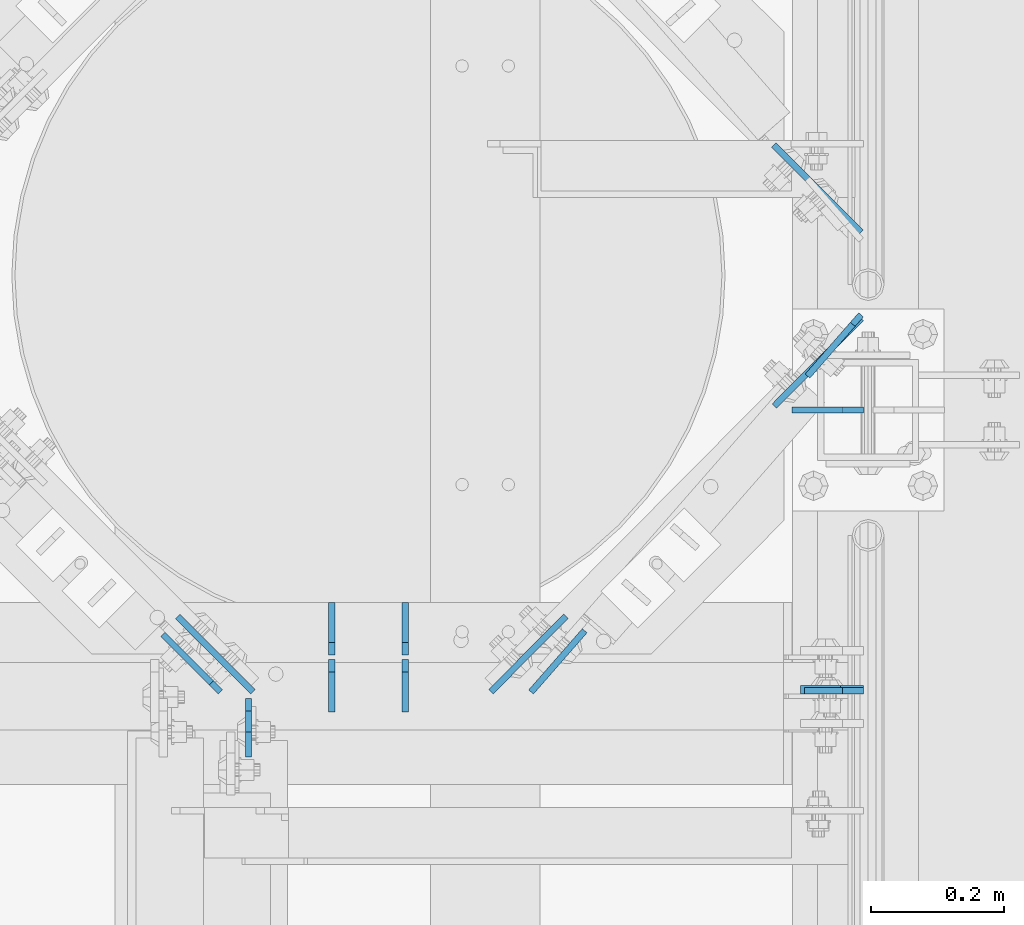
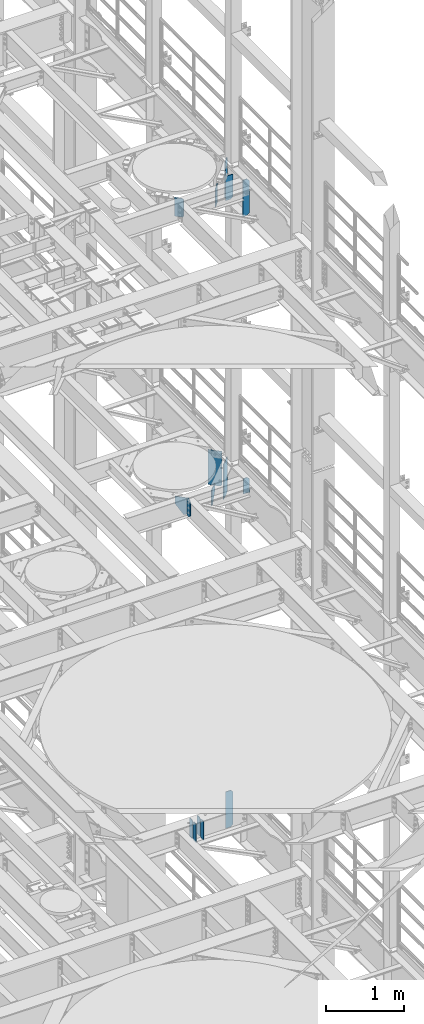
# One storey, part 1652 of 1876: 16 plates, 6 elements without a shape of their own.
"""IFC2X3 building model written with IfcOpenShell, lengths in millimetres."""

from ifc_helpers import new_model, si_unit, frame, origin_with_axes, place, context, subcontext, project, spatial, faceted_brep, material, type_object, element, aggregate, save


model = new_model("IFC2X3")

# Units and contexts
model_context = context("Model", 3, precision=1e-05, world=origin_with_axes())
body_context = subcontext(model_context, "Body", "Model", "MODEL_VIEW")
ifc_project = project(units=[si_unit("LENGTHUNIT", "METRE", prefix="MILLI"), si_unit("AREAUNIT", "SQUARE_METRE"), si_unit("VOLUMEUNIT", "CUBIC_METRE"), si_unit("MASSUNIT", "GRAM", prefix="KILO"), si_unit("TIMEUNIT", "SECOND"), si_unit("PLANEANGLEUNIT", "RADIAN"), si_unit("SOLIDANGLEUNIT", "STERADIAN"), si_unit("THERMODYNAMICTEMPERATUREUNIT", "DEGREE_CELSIUS"), si_unit("LUMINOUSINTENSITYUNIT", "LUMEN")], contexts=[model_context])

# Site, building, storey
site_placement = place(None, origin_with_axes())
site = spatial("IfcSite", under=ifc_project, at=site_placement, CompositionType="ELEMENT")
building_placement = place(site_placement, origin_with_axes())
building = spatial("IfcBuilding", under=site, at=building_placement, Name="Undefined", CompositionType="ELEMENT")
storey_placement = place(building_placement, origin_with_axes())
storey = spatial("IfcBuildingStorey", under=building, at=storey_placement, Name="Undefined", CompositionType="ELEMENT", Elevation=0.0)

# Assembly, plate
assembly_1_placement = place(storey_placement, origin_with_axes())
assembly_1 = element("IfcElementAssembly", 1, at=assembly_1_placement, inside=storey, Name="BEAM", AssemblyPlace="NOTDEFINED", PredefinedType="RIGID_FRAME")
ifc_material = material(Name="STEEL/A36")
plate_type_1 = type_object("IfcPlateType", PredefinedType="NOTDEFINED")
plate_1_placement = place(assembly_1_placement, frame((7612.85625, 3132.13799991608, 13042.9), z_axis=(0.0, 0.0, 1.0), x_axis=(-1.0, 0.0, 0.0)))
plate_1 = element("IfcPlate", 2, at=plate_1_placement, type_object=plate_type_1, material=ifc_material, Name="PLATE", context=body_context, shape_type="Brep", body=[
    faceted_brep([(0.0, -4.76249999999982, 0.0), (0.0, -4.76249999999982, 209.550003051758), (0.0, 4.76249999999982, 209.550003051758), (0.0, 4.76249999999982, 0.0), (31.75, -4.76249999999982, 241.300003051758), (31.75, 4.76249999999982, 241.300003051758), (88.9000015258788, -4.76249999999982, 241.300003051758), (88.9000015258788, 4.76249999999982, 241.300003051758), (88.9000015258789, -4.76249999999982, 0.0), (88.9000015258789, 4.76249999999982, 0.0)], [[[0, 1, 2, 3]], [[1, 4, 5, 2]], [[4, 6, 7, 5]], [[6, 8, 9, 7]], [[8, 0, 3, 9]], [[5, 7, 9, 3, 2]], [[8, 6, 4, 1, 0]]]),
])

assembly_2_placement = place(storey_placement, origin_with_axes())
assembly_2 = element("IfcElementAssembly", 3, at=assembly_2_placement, inside=storey, Name="BEAM", AssemblyPlace="NOTDEFINED", PredefinedType="RIGID_FRAME")
plate_2_placement = place(assembly_2_placement, frame((6684.96200008392, 3121.025, 13012.7375), z_axis=(0.0, 0.0, 1.0), x_axis=(0.0, -1.0, 0.0)))
plate_2 = element("IfcPlate", 4, at=plate_2_placement, type_object=plate_type_1, material=ifc_material, Name="PLATE", context=body_context, shape_type="Brep", body=[
    faceted_brep([(0.0, -4.76249999999982, 19.0499992370605), (0.0, -4.76249999999982, 271.462512969971), (0.0, 4.76249999999982, 271.462512969971), (0.0, 4.76249999999982, 19.0499992370605), (19.0499992370605, -4.76249999999982, 290.512512207031), (19.0499992370605, 4.76249999999982, 290.512512207031), (50.8000030517578, -4.76249999999982, 290.512512207031), (50.8000030517578, 4.76249999999982, 290.512512207031), (88.9000015258789, -4.76249999999982, 252.41251373291), (88.9000015258789, 4.76249999999982, 252.41251373291), (88.9000015258789, -4.76249999999982, 38.0999984741211), (88.9000015258789, 4.76249999999982, 38.0999984741211), (50.8000030517578, -4.76249999999982, 0.0), (50.8000030517578, 4.76249999999982, 0.0), (19.0499992370605, -4.76249999999982, 0.0), (19.0499992370605, 4.76249999999982, 0.0)], [[[0, 1, 2, 3]], [[1, 4, 5, 2]], [[4, 6, 7, 5]], [[6, 8, 9, 7]], [[8, 10, 11, 9]], [[10, 12, 13, 11]], [[12, 14, 15, 13]], [[14, 0, 3, 15]], [[5, 7, 9, 11, 13, 15, 3, 2]], [[14, 12, 10, 8, 6, 4, 1, 0]]]),
])

# Plate
plate_type_2 = type_object("IfcPlateType", PredefinedType="NOTDEFINED")
plate_3_placement = place(assembly_1_placement, frame((7609.47565435751, 3693.89456509055, 13262.5836968558), z_axis=(-0.704366743820441, -0.709836241819047, 0.0), x_axis=(0.0, 0.0, -1.0)))
plate_3 = element("IfcPlate", 5, at=plate_3_placement, type_object=plate_type_2, material=ifc_material, Name="PLATE", context=body_context, shape_type="Brep", body=[
    faceted_brep([(0.0, -4.76249999999982, 0.0), (0.0, -4.76249999994798, 186.231414794903), (0.0, 4.76250000005439, 186.231414794904), (0.0, 4.76249999999982, 0.0), (549.870300292969, -4.76249999994798, 186.231414794903), (549.870300292969, 4.76250000005439, 186.231414794904), (549.870300292969, -4.76249999999345, 25.3999996185275), (549.870300292969, 4.76250000000891, 25.3999996185275), (524.470300674438, -4.76249999999982, 0.0), (524.470300674438, 4.76250000000164, 0.0)], [[[0, 1, 2, 3]], [[1, 4, 5, 2]], [[4, 6, 7, 5]], [[6, 8, 9, 7]], [[8, 0, 3, 9]], [[5, 7, 9, 3, 2]], [[8, 6, 4, 1, 0]]]),
])

plate_4_placement = place(assembly_1_placement, frame((7609.49326370708, 3824.22401123438, 13258.8), z_axis=(-0.708073497960695, 0.706138740960801, 0.0), x_axis=(0.0, 0.0, -1.0)))
plate_4 = element("IfcPlate", 6, at=plate_4_placement, type_object=plate_type_2, material=ifc_material, Name="PLATE", context=body_context, shape_type="Brep", body=[
    faceted_brep([(0.0, -4.76249999999982, 0.0), (0.0, -4.7624999999789, 186.237014770529), (0.0, 4.76250000002528, 186.237014770531), (0.0, 4.76249999999982, 0.0), (546.099975585938, -4.7624999999789, 186.237014770529), (546.099975585938, 4.76250000002528, 186.237014770531), (546.099975585938, -4.76249999999982, 25.3999996185325), (546.099975585938, 4.76250000000437, 25.3999996185344), (520.699975967407, -4.76250000000255, -1.36424205265939e-12), (520.699975967407, 4.76250000000073, 9.09494701772928e-13)], [[[0, 1, 2, 3]], [[1, 4, 5, 2]], [[4, 6, 7, 5]], [[6, 8, 9, 7]], [[8, 0, 3, 9]], [[5, 7, 9, 3, 2]], [[8, 6, 4, 1, 0]]]),
])

aggregate(assembly_1, [plate_3, plate_4, plate_1])

# Assembly, plate
assembly_3_placement = place(storey_placement, origin_with_axes())
assembly_3 = element("IfcElementAssembly", 7, at=assembly_3_placement, inside=storey, Name="BEAM", AssemblyPlace="NOTDEFINED", PredefinedType="RIGID_FRAME")
plate_type_3 = type_object("IfcPlateType", PredefinedType="NOTDEFINED")
plate_5_placement = place(assembly_3_placement, frame((7612.85625, 3133.72500009537, 17387.8875), z_axis=(0.0, 0.0, 1.0), x_axis=(-1.0, 0.0, 0.0)))
plate_5 = element("IfcPlate", 8, at=plate_5_placement, type_object=plate_type_3, material=ifc_material, Name="PLATE", context=body_context, shape_type="Brep", body=[
    faceted_brep([(0.0, -6.34999999999991, 34.9249992370605), (0.0, -6.34999999999991, 534.987476348877), (0.0, 6.34999999999991, 534.987476348877), (0.0, 6.34999999999991, 34.9249992370605), (34.9249992370605, -6.34999999999991, 569.912475585938), (34.9249992370605, 6.34999999999991, 569.912475585938), (95.25, -6.35000000000036, 569.912475585938), (95.25, 6.35000000000036, 569.912475585938), (95.25, -6.35000000000036, 0.0), (95.25, 6.35000000000036, 0.0), (34.9249992370605, -6.34999999999991, 0.0), (34.9249992370605, 6.34999999999991, 0.0)], [[[0, 1, 2, 3]], [[1, 4, 5, 2]], [[4, 6, 7, 5]], [[6, 8, 9, 7]], [[8, 10, 11, 9]], [[10, 0, 3, 11]], [[5, 7, 9, 11, 3, 2]], [[10, 8, 6, 4, 1, 0]]]),
])

# Assembly, plates
assembly_4_placement = place(storey_placement, origin_with_axes())
assembly_4 = element("IfcElementAssembly", 9, at=assembly_4_placement, inside=storey, Name="BEAM", AssemblyPlace="NOTDEFINED", PredefinedType="RIGID_FRAME")
plate_type_4 = type_object("IfcPlateType", PredefinedType="NOTDEFINED")
plate_6_placement = place(assembly_4_placement, frame((6921.4995, 3100.3875, 7850.1875), z_axis=(0.0, 0.0, 1.0), x_axis=(0.0, 1.0, 0.0)))
plate_6 = element("IfcPlate", 10, at=plate_6_placement, type_object=plate_type_4, material=ifc_material, Name="PLATE", context=body_context, shape_type="Brep", body=[
    faceted_brep([(0.0, -4.76249999999982, 0.0), (0.0, -4.76249999999982, 292.100006103516), (0.0, 4.76249999999982, 292.100006103516), (0.0, 4.76249999999982, 0.0), (60.3250007629395, -4.76249999999982, 292.100006103516), (60.3250007629395, 4.76249999999982, 292.100006103516), (79.375, -4.76249999999982, 273.050006866455), (79.375, 4.76249999999982, 273.050006866455), (79.375, -4.76249999999982, 19.0499992370605), (79.375, 4.76249999999982, 19.0499992370605), (60.3250007629395, -4.76249999999982, 0.0), (60.3250007629395, 4.76249999999982, 0.0)], [[[0, 1, 2, 3]], [[1, 4, 5, 2]], [[4, 6, 7, 5]], [[6, 8, 9, 7]], [[8, 10, 11, 9]], [[10, 0, 3, 11]], [[5, 7, 9, 11, 3, 2]], [[10, 8, 6, 4, 1, 0]]]),
])
plate_7_placement = place(assembly_4_placement, frame((6921.4995, 3186.1125, 7850.1875), z_axis=(0.0, 0.0, 1.0), x_axis=(0.0, 1.0, 0.0)))
plate_7 = element("IfcPlate", 11, at=plate_7_placement, type_object=plate_type_4, material=ifc_material, Name="PLATE", context=body_context, shape_type="Brep", body=[
    faceted_brep([(0.0, -4.76249999999982, 19.0499992370605), (0.0, -4.76249999999982, 273.050006866455), (0.0, 4.76249999999982, 273.050006866455), (0.0, 4.76249999999982, 19.0499992370605), (19.0499992370605, -4.76249999999982, 292.100006103516), (19.0499992370605, 4.76249999999982, 292.100006103516), (79.375, -4.76249999999982, 292.100006103516), (79.375, 4.76249999999982, 292.100006103516), (79.375, -4.76250000000073, 0.0), (79.375, 4.76250000000073, 0.0), (19.0499992370605, -4.76249999999982, 0.0), (19.0499992370605, 4.76249999999982, 0.0)], [[[0, 1, 2, 3]], [[1, 4, 5, 2]], [[4, 6, 7, 5]], [[6, 8, 9, 7]], [[8, 10, 11, 9]], [[10, 0, 3, 11]], [[5, 7, 9, 11, 3, 2]], [[10, 8, 6, 4, 1, 0]]]),
])
plate_8_placement = place(assembly_4_placement, frame((6810.375, 3100.3875, 7850.1875), z_axis=(0.0, 0.0, 1.0), x_axis=(0.0, 1.0, 0.0)))
plate_8 = element("IfcPlate", 12, at=plate_8_placement, type_object=plate_type_4, material=ifc_material, Name="PLATE", context=body_context, shape_type="Brep", body=[
    faceted_brep([(0.0, -4.76249999999982, 0.0), (0.0, -4.76249999999982, 292.100006103516), (0.0, 4.76249999999982, 292.100006103516), (0.0, 4.76249999999982, 0.0), (60.3250007629395, -4.76249999999982, 292.100006103516), (60.3250007629395, 4.76249999999982, 292.100006103516), (79.375, -4.76249999999982, 273.050006866455), (79.375, 4.76249999999982, 273.050006866455), (79.375, -4.76249999999982, 19.0499992370605), (79.375, 4.76249999999982, 19.0499992370605), (60.3250007629395, -4.76249999999982, 0.0), (60.3250007629395, 4.76249999999982, 0.0)], [[[0, 1, 2, 3]], [[1, 4, 5, 2]], [[4, 6, 7, 5]], [[6, 8, 9, 7]], [[8, 10, 11, 9]], [[10, 0, 3, 11]], [[5, 7, 9, 11, 3, 2]], [[10, 8, 6, 4, 1, 0]]]),
])
plate_9_placement = place(assembly_4_placement, frame((6810.375, 3186.1125, 7850.1875), z_axis=(0.0, 0.0, 1.0), x_axis=(0.0, 1.0, 0.0)))
plate_9 = element("IfcPlate", 13, at=plate_9_placement, type_object=plate_type_4, material=ifc_material, Name="PLATE", context=body_context, shape_type="Brep", body=[
    faceted_brep([(0.0, -4.76249999999982, 19.0499992370605), (0.0, -4.76249999999982, 273.050006866455), (0.0, 4.76249999999982, 273.050006866455), (0.0, 4.76249999999982, 19.0499992370605), (19.0499992370605, -4.76249999999982, 292.100006103516), (19.0499992370605, 4.76249999999982, 292.100006103516), (79.375, -4.76249999999982, 292.100006103516), (79.375, 4.76249999999982, 292.100006103516), (79.375, -4.76250000000073, 0.0), (79.375, 4.76250000000073, 0.0), (19.0499992370605, -4.76249999999982, 0.0), (19.0499992370605, 4.76249999999982, 0.0)], [[[0, 1, 2, 3]], [[1, 4, 5, 2]], [[4, 6, 7, 5]], [[6, 8, 9, 7]], [[8, 10, 11, 9]], [[10, 0, 3, 11]], [[5, 7, 9, 11, 3, 2]], [[10, 8, 6, 4, 1, 0]]]),
])
aggregate(assembly_4, [plate_6, plate_7, plate_8, plate_9])

# Plate
plate_type_5 = type_object("IfcPlateType", PredefinedType="NOTDEFINED")
plate_10_placement = place(assembly_3_placement, frame((7612.85625, 3556.0, 17386.3), z_axis=(0.0, 0.0, 1.0), x_axis=(-1.0, 0.0, 0.0)))
plate_10 = element("IfcPlate", 14, at=plate_10_placement, type_object=plate_type_5, material=ifc_material, Name="PLATE", context=body_context, shape_type="Brep", body=[
    faceted_brep([(-9.76996261670138e-14, -4.76250000000073, 31.75), (0.0, -4.76250000000073, 381.0), (0.0, 4.76250000000073, 381.0), (-9.76996261670138e-14, 4.76250000000073, 31.75), (107.949996948242, -4.76249999999982, 381.0), (107.949996948242, 4.76249999999982, 381.0), (107.950006484985, -4.76250000000073, 0.0), (107.950006484985, 4.76250000000073, 0.0), (31.75, -4.76250000000073, 0.0), (31.75, 4.76250000000073, 0.0)], [[[0, 1, 2, 3]], [[1, 4, 5, 2]], [[4, 6, 7, 5]], [[6, 8, 9, 7]], [[8, 0, 3, 9]], [[5, 7, 9, 3, 2]], [[8, 6, 4, 1, 0]]]),
])

# Assembly, plate
assembly_5_placement = place(storey_placement, origin_with_axes())
assembly_5 = element("IfcElementAssembly", 15, at=assembly_5_placement, inside=storey, Name="BEAM", AssemblyPlace="NOTDEFINED", PredefinedType="RIGID_FRAME")
plate_11_placement = place(assembly_5_placement, frame((7612.85625, 3556.0, 7556.5), z_axis=(0.0, 0.0, 1.0), x_axis=(-1.0, 0.0, 0.0)))
plate_11 = element("IfcPlate", 16, at=plate_11_placement, type_object=plate_type_5, material=ifc_material, Name="PLATE", context=body_context, shape_type="Brep", body=[
    faceted_brep([(-9.76996261670138e-14, -4.76250000000073, 31.75), (0.0, -4.76249999999982, 539.75), (0.0, 4.76249999999982, 539.75), (-9.76996261670138e-14, 4.76250000000073, 31.75), (31.75, -4.76249999999982, 571.5), (31.75, 4.76249999999982, 571.5), (107.949996948242, -4.76249999999982, 571.5), (107.949996948242, 4.76249999999982, 571.5), (107.950006484985, -4.76250000000073, 0.0), (107.950006484985, 4.76250000000073, 0.0), (31.75, -4.76250000000073, 0.0), (31.75, 4.76250000000073, 0.0)], [[[0, 1, 2, 3]], [[1, 4, 5, 2]], [[4, 6, 7, 5]], [[6, 8, 9, 7]], [[8, 10, 11, 9]], [[10, 0, 3, 11]], [[5, 7, 9, 11, 3, 2]], [[10, 8, 6, 4, 1, 0]]]),
])
aggregate(assembly_5, [plate_11])

# Plate
plate_type_6 = type_object("IfcPlateType", PredefinedType="NOTDEFINED")
plate_12_placement = place(assembly_3_placement, frame((7609.27210406505, 3699.59418728868, 17956.2125), z_axis=(-0.658504607797722, -0.752576694768824, 0.0), x_axis=(0.0, 0.0, -1.0)))
plate_12 = element("IfcPlate", 17, at=plate_12_placement, type_object=plate_type_6, material=ifc_material, Name="PLATE", context=body_context, shape_type="Brep", body=[
    faceted_brep([(0.0, -4.76249999999982, 19.0499992370605), (0.0, -4.7624999999698, 122.700408935563), (0.0, 4.76250000003165, 122.700408935567), (0.0, 4.76249999999982, 19.0499992370605), (569.912475585938, -4.7624999999698, 122.700408935563), (569.912475585938, 4.76250000003165, 122.700408935567), (569.912475585938, -4.76250000000618, 19.0499992370651), (569.912475585938, 4.76249999999573, 19.0499992370624), (550.862476348877, -4.76250000000118, 2.72848410531878e-12), (550.862476348877, 4.76250000000073, -9.09494701772928e-13), (19.0499992370605, -4.76249999999982, 0.0), (19.0499992370605, 4.76249999999982, 0.0)], [[[0, 1, 2, 3]], [[1, 4, 5, 2]], [[4, 6, 7, 5]], [[6, 8, 9, 7]], [[8, 10, 11, 9]], [[10, 0, 3, 11]], [[5, 7, 9, 11, 3, 2]], [[10, 8, 6, 4, 1, 0]]]),
])

aggregate(assembly_3, [plate_12, plate_10, plate_5])

# Assembly, plates
assembly_6_placement = place(storey_placement, origin_with_axes())
assembly_6 = element("IfcElementAssembly", 18, at=assembly_6_placement, inside=storey, Name="BEAM", AssemblyPlace="NOTDEFINED", PredefinedType="RIGID_FRAME")
plate_13_placement = place(assembly_6_placement, frame((7111.32442701366, 3130.51112769206, 17975.2625), z_axis=(0.658504607797722, 0.752576694768825, 0.0), x_axis=(0.0, 0.0, -1.0)))
plate_13 = element("IfcPlate", 19, at=plate_13_placement, type_object=plate_type_6, material=ifc_material, Name="PLATE", context=body_context, shape_type="Brep", body=[
    faceted_brep([(0.0, -4.76249999999982, 0.0), (0.0, -4.762500000008, 122.840980529847), (0.0, 4.76249999999709, 122.840980529847), (0.0, 4.76249999999982, 0.0), (290.512481689453, -4.762500000008, 122.840980529847), (290.512481689453, 4.76249999999709, 122.840980529847), (290.512481689453, -4.76250000000164, 9.09494701772928e-13), (290.512481689453, 4.76250000000118, -2.72848410531878e-12)], [[[0, 1, 2, 3]], [[1, 4, 5, 2]], [[4, 6, 7, 5]], [[6, 0, 3, 7]], [[5, 7, 3, 2]], [[6, 4, 1, 0]]]),
])
plate_14_placement = place(assembly_6_placement, frame((6642.42488190258, 3130.74260103517, 17975.2625), z_axis=(-0.707107495686184, 0.707106066686189, 0.0), x_axis=(0.0, 0.0, -1.0)))
plate_14 = element("IfcPlate", 20, at=plate_14_placement, type_object=plate_type_6, material=ifc_material, Name="PLATE", context=body_context, shape_type="Brep", body=[
    faceted_brep([(0.0, -4.76249999999982, 19.0499992370605), (0.0, -4.76250000000073, 122.73646545413), (0.0, 4.76250000000164, 122.736465454129), (0.0, 4.76249999999982, 19.0499992370605), (290.512481689453, -4.76250000000073, 122.73646545413), (290.512481689453, 4.76250000000164, 122.736465454129), (290.512481689453, -4.76250000000255, 19.0499992370701), (290.512481689453, 4.76250000000073, 19.0499992370701), (271.462482452393, -4.76250000000255, -9.09494701772928e-13), (271.462482452393, 4.76250000000255, -4.54747350886464e-13), (19.0499992370605, -4.76249999999982, 0.0), (19.0499992370605, 4.76249999999982, 0.0)], [[[0, 1, 2, 3]], [[1, 4, 5, 2]], [[4, 6, 7, 5]], [[6, 8, 9, 7]], [[8, 10, 11, 9]], [[10, 0, 3, 11]], [[5, 7, 9, 11, 3, 2]], [[10, 8, 6, 4, 1, 0]]]),
])
aggregate(assembly_6, [plate_13, plate_14])

# Plate
plate_type_7 = type_object("IfcPlateType", PredefinedType="NOTDEFINED")
plate_15_placement = place(assembly_2_placement, frame((7050.6499892987, 3130.72954715505, 13267.8433148993), z_axis=(0.704366743820441, 0.709836241819047, 0.0), x_axis=(0.0, 0.0, -1.0)))
plate_15 = element("IfcPlate", 21, at=plate_15_placement, type_object=plate_type_7, material=ifc_material, Name="PLATE", context=body_context, shape_type="Brep", body=[
    faceted_brep([(0.0, -4.76249999999982, 0.0), (0.0, -4.76249999995571, 160.839843749984), (0.0, 4.76250000004666, 160.839843749984), (0.0, 4.76249999999982, 0.0), (237.728137969971, -4.76250000000027, -9.09494701772928e-13), (237.728137969971, 4.76250000000118, -9.09494701772928e-13), (256.778137207031, -4.76249999999573, 19.0499992370587), (256.778137207031, 4.76250000000709, 19.0499992370587), (256.778137207031, -4.76249999998663, 50.8000003324114), (110.643315428239, -4.76249999995571, 160.839843749984), (110.643315428248, 4.76250000004666, 160.839843749984), (256.778137207031, 4.76250000001528, 50.8000003324196)], [[[0, 1, 2, 3]], [[4, 0, 3, 5]], [[6, 4, 5, 7]], [[1, 0, 4, 6, 8, 9]], [[2, 1, 9, 10]], [[7, 5, 3, 2, 10, 11]], [[6, 7, 11, 8]], [[10, 9, 8, 11]]]),
])

plate_16_placement = place(assembly_2_placement, frame((6691.81637274208, 3130.74260211412, 13275.2197708386), z_axis=(-0.707107495686184, 0.707106066686189, 0.0), x_axis=(0.0, 0.0, -1.0)))
plate_16 = element("IfcPlate", 22, at=plate_16_placement, type_object=plate_type_7, material=ifc_material, Name="PLATE", context=body_context, shape_type="Brep", body=[
    faceted_brep([(0.0, -4.76249999999982, 0.0), (0.0, -4.76250000000073, 160.835510253944), (0.0, 4.76250000000073, 160.835510253944), (0.0, 4.76249999999982, 0.0), (245.070301055908, -4.76250000000073, 1.81898940354586e-12), (245.070301055908, 4.76250000000255, 9.09494701772928e-13), (264.120300292969, -4.76249999999891, 19.0499992370651), (264.120300292969, 4.76250000000073, 19.0499992370651), (264.120300292969, -4.76250000000164, 50.7693369250605), (118.019770468451, -4.76250000000073, 160.835510253944), (118.026066609118, 4.76250000000073, 160.835510253944), (264.120300292969, 4.76250000000164, 50.7740801803438)], [[[0, 1, 2, 3]], [[4, 0, 3, 5]], [[6, 4, 5, 7]], [[1, 0, 4, 6, 8, 9]], [[2, 1, 9, 10]], [[7, 5, 3, 2, 10, 11]], [[6, 7, 11, 8]], [[10, 9, 8, 11]]]),
])

aggregate(assembly_2, [plate_15, plate_16, plate_2])

save(model, "model.ifc")
